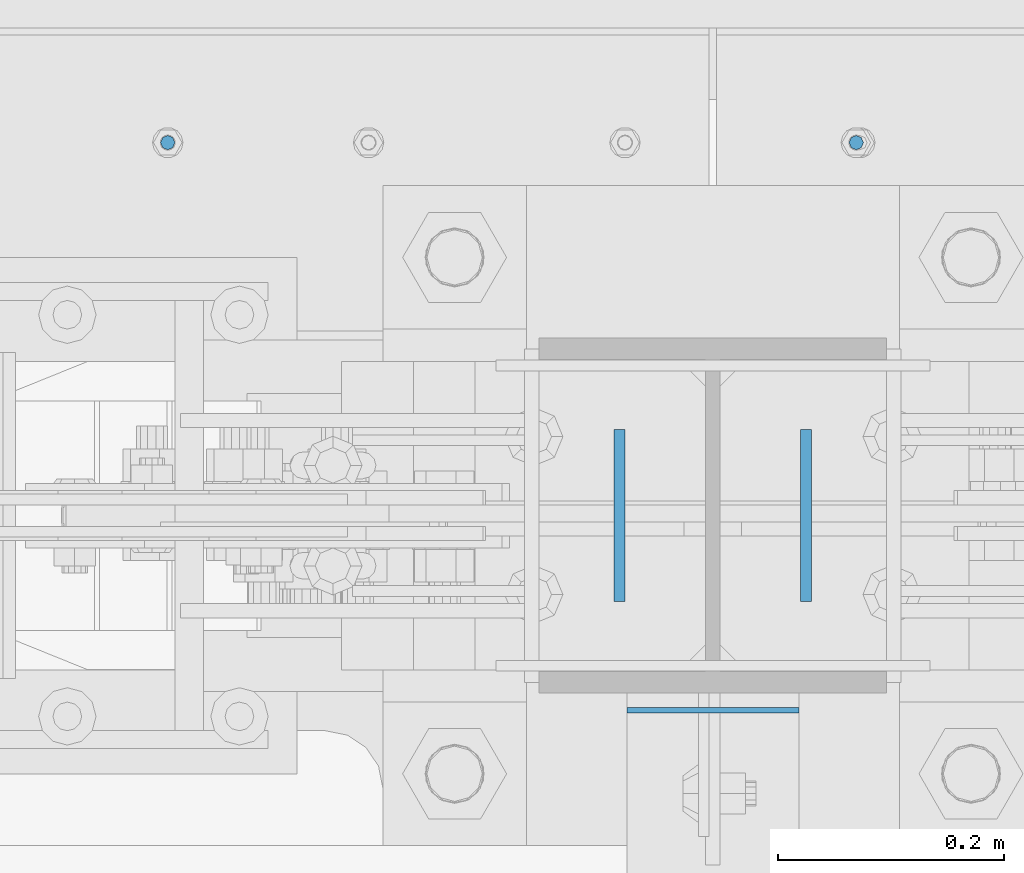
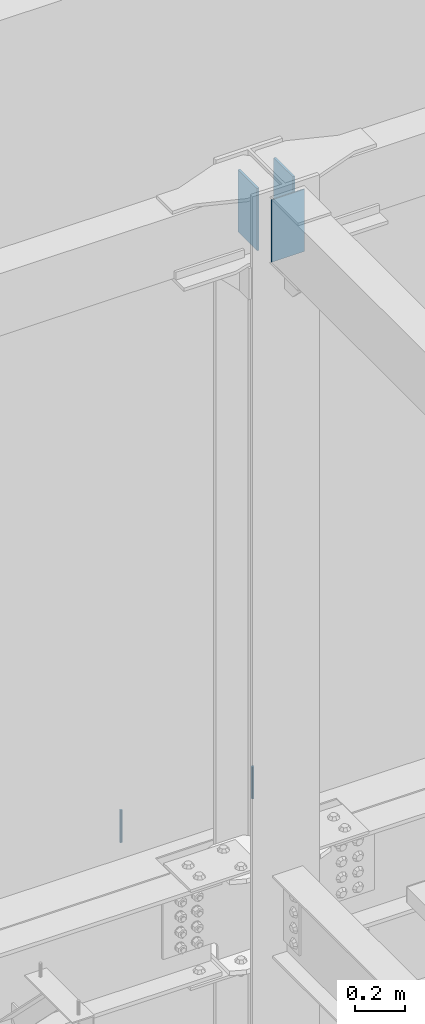
# One storey, part 528 of 1179: 5 columns, 5 elements without a shape of their own.
"""IFC2X3 building model written with IfcOpenShell, lengths in millimetres."""

from ifc_helpers import new_model, si_unit, frame, origin_with_axes, place, context, subcontext, project, spatial, faceted_brep, material, type_object, element, aggregate, save


model = new_model("IFC2X3")

# Units and contexts
model_context = context("Model", 3, precision=1e-05, world=origin_with_axes())
body_context = subcontext(model_context, "Body", "Model", "MODEL_VIEW")
ifc_project = project(units=[si_unit("LENGTHUNIT", "METRE", prefix="MILLI"), si_unit("AREAUNIT", "SQUARE_METRE"), si_unit("VOLUMEUNIT", "CUBIC_METRE"), si_unit("MASSUNIT", "GRAM", prefix="KILO"), si_unit("TIMEUNIT", "SECOND"), si_unit("PLANEANGLEUNIT", "RADIAN"), si_unit("SOLIDANGLEUNIT", "STERADIAN"), si_unit("THERMODYNAMICTEMPERATUREUNIT", "DEGREE_CELSIUS"), si_unit("LUMINOUSINTENSITYUNIT", "LUMEN")], contexts=[model_context])

# Site, building, storey
site_placement = place(None, origin_with_axes())
site = spatial("IfcSite", under=ifc_project, at=site_placement, CompositionType="ELEMENT")
building_placement = place(site_placement, origin_with_axes())
building = spatial("IfcBuilding", under=site, at=building_placement, Name="Undefined", CompositionType="ELEMENT")
storey_placement = place(building_placement, origin_with_axes())
storey = spatial("IfcBuildingStorey", under=building, at=storey_placement, Name="Undefined", CompositionType="ELEMENT", Elevation=0.0)

# Assembly, column
assembly_1_placement = place(storey_placement, origin_with_axes())
assembly_1 = element("IfcElementAssembly", 1, at=assembly_1_placement, inside=storey, Name="BEAM", AssemblyPlace="NOTDEFINED", PredefinedType="RIGID_FRAME")
ifc_material_1 = material(Name="STEEL/A307")
column_type_1 = type_object("IfcColumnType", PredefinedType="NOTDEFINED")
column_1_placement = place(assembly_1_placement, frame((7797.8, 41529.0, 13125.45), z_axis=(0.0, 1.0, 0.0), x_axis=(0.0, 0.0, 1.0)))
column_1 = element("IfcColumn", 2, at=column_1_placement, type_object=column_type_1, material=ifc_material_1, Name="THREADED ROD", context=body_context, shape_type="Brep", body=[
    faceted_brep([(0.0, -6.34999999999854, 0.0), (0.0, -4.49012806053361, -4.49012806053452), (157.162499999999, -4.49012806053361, -4.49012806053361), (157.162499999999, -6.34999999999854, 0.0), (0.0, 0.0, -6.34999999999991), (157.162499999999, 0.0, -6.34999999999854), (0.0, 4.49012806053361, -4.49012806053452), (157.162499999999, 4.49012806053361, -4.49012806053361), (0.0, 6.34999999999854, 0.0), (157.162499999999, 6.34999999999854, 0.0), (0.0, 4.49012806053361, 4.49012806053452), (157.162499999999, 4.49012806053361, 4.49012806053361), (0.0, 0.0, 6.34999999999991), (157.162499999999, 0.0, 6.34999999999854), (0.0, -4.49012806053361, 4.49012806053452), (157.162499999999, -4.49012806053361, 4.49012806053361)], [[[0, 1, 2, 3]], [[1, 4, 5, 2]], [[4, 6, 7, 5]], [[6, 8, 9, 7]], [[8, 10, 11, 9]], [[10, 12, 13, 11]], [[12, 14, 15, 13]], [[14, 0, 3, 15]], [[5, 7, 9, 11, 13, 15, 3, 2]], [[14, 12, 10, 8, 6, 4, 1, 0]]]),
])
aggregate(assembly_1, [column_1])

assembly_2_placement = place(storey_placement, origin_with_axes())
assembly_2 = element("IfcElementAssembly", 3, at=assembly_2_placement, inside=storey, Name="BEAM", AssemblyPlace="NOTDEFINED", PredefinedType="RIGID_FRAME")
column_2_placement = place(assembly_2_placement, frame((8407.4, 41529.0, 13125.45), z_axis=(0.0, 1.0, 0.0), x_axis=(0.0, 0.0, 1.0)))
column_2 = element("IfcColumn", 4, at=column_2_placement, type_object=column_type_1, material=ifc_material_1, Name="THREADED ROD", context=body_context, shape_type="Brep", body=[
    faceted_brep([(0.0, -6.34999999999854, 0.0), (0.0, -4.49012806053361, -4.49012806053452), (157.162499999999, -4.49012806053361, -4.49012806053361), (157.162499999999, -6.34999999999854, 0.0), (0.0, 0.0, -6.34999999999991), (157.162499999999, 0.0, -6.34999999999854), (0.0, 4.49012806053361, -4.49012806053452), (157.162499999999, 4.49012806053361, -4.49012806053361), (0.0, 6.34999999999854, 0.0), (157.162499999999, 6.34999999999854, 0.0), (0.0, 4.49012806053361, 4.49012806053452), (157.162499999999, 4.49012806053361, 4.49012806053361), (0.0, 0.0, 6.34999999999991), (157.162499999999, 0.0, 6.34999999999854), (0.0, -4.49012806053361, 4.49012806053452), (157.162499999999, -4.49012806053361, 4.49012806053361)], [[[0, 1, 2, 3]], [[1, 4, 5, 2]], [[4, 6, 7, 5]], [[6, 8, 9, 7]], [[8, 10, 11, 9]], [[10, 12, 13, 11]], [[12, 14, 15, 13]], [[14, 0, 3, 15]], [[5, 7, 9, 11, 13, 15, 3, 2]], [[14, 12, 10, 8, 6, 4, 1, 0]]]),
])
aggregate(assembly_2, [column_2])

assembly_3_placement = place(storey_placement, origin_with_axes())
assembly_3 = element("IfcElementAssembly", 5, at=assembly_3_placement, inside=storey, Name="BEAM", AssemblyPlace="NOTDEFINED", PredefinedType="RIGID_FRAME")
ifc_material_2 = material(Name="STEEL/A36")
column_type_2 = type_object("IfcColumnType", PredefinedType="NOTDEFINED")
column_3_placement = place(assembly_3_placement, frame((8197.84999897387, 41198.8, 16122.65), z_axis=(0.0, 1.0, 0.0), x_axis=(0.0, 0.0, 1.0)))
column_3 = element("IfcColumn", 6, at=column_3_placement, type_object=column_type_2, material=ifc_material_2, Name="PLATE", context=body_context, shape_type="Brep", body=[
    faceted_brep([(0.0, 4.76249999999982, -76.1999999999971), (0.0, 4.76249999999982, 76.1999999999971), (304.799999999999, 4.76250000000073, 76.1999999999971), (304.799999999999, 4.76250000000073, -76.1999999999971), (0.0, -4.76249999999982, 76.1999999999971), (304.799999999999, -4.76250000000073, 76.1999999999971), (0.0, -4.76249999999982, -76.1999999999971), (304.799999999999, -4.76250000000073, -76.1999999999971)], [[[0, 1, 2, 3]], [[1, 4, 5, 2]], [[4, 6, 7, 5]], [[6, 0, 3, 7]], [[5, 7, 3, 2]], [[6, 4, 1, 0]]]),
])
aggregate(assembly_3, [column_3])

assembly_4_placement = place(storey_placement, origin_with_axes())
assembly_4 = element("IfcElementAssembly", 7, at=assembly_4_placement, inside=storey, Name="BEAM", AssemblyPlace="NOTDEFINED", PredefinedType="RIGID_FRAME")
column_4_placement = place(assembly_4_placement, frame((8362.95000000001, 41198.8, 16122.65), z_axis=(0.0, -1.0, 0.0), x_axis=(0.0, 0.0, 1.0)))
column_4 = element("IfcColumn", 8, at=column_4_placement, type_object=column_type_2, material=ifc_material_2, Name="PLATE", context=body_context, shape_type="Brep", body=[
    faceted_brep([(0.0, 4.76249999999982, -76.1999999999971), (0.0, 4.76249999999982, 76.1999999999971), (304.799999999999, 4.76250000000073, 76.1999999999971), (304.799999999999, 4.76250000000073, -76.1999999999971), (0.0, -4.76249999999982, 76.1999999999971), (304.799999999999, -4.76250000000073, 76.1999999999971), (0.0, -4.76249999999982, -76.1999999999971), (304.799999999999, -4.76250000000073, -76.1999999999971)], [[[0, 1, 2, 3]], [[1, 4, 5, 2]], [[4, 6, 7, 5]], [[6, 0, 3, 7]], [[5, 7, 3, 2]], [[6, 4, 1, 0]]]),
])
aggregate(assembly_4, [column_4])

assembly_5_placement = place(storey_placement, origin_with_axes())
assembly_5 = element("IfcElementAssembly", 9, at=assembly_5_placement, inside=storey, Name="BEAM", AssemblyPlace="NOTDEFINED", PredefinedType="RIGID_FRAME")
column_type_3 = type_object("IfcColumnType", PredefinedType="NOTDEFINED")
column_5_placement = place(assembly_5_placement, frame((8280.4, 41026.5565, 16122.65), z_axis=(-1.0, 0.0, 0.0), x_axis=(0.0, 0.0, 1.0)))
column_5 = element("IfcColumn", 10, at=column_5_placement, type_object=column_type_3, material=ifc_material_2, Name="PLATE", context=body_context, shape_type="Brep", body=[
    faceted_brep([(0.0, 2.38150000000041, -76.1999999999998), (0.0, 2.38150000000041, 76.1999999999998), (304.799999999999, 2.38150000000314, 76.2), (304.799999999999, 2.38150000000314, -76.2), (0.0, -2.38150000000041, 76.1999999999998), (304.799999999999, -2.38150000000314, 76.2), (0.0, -2.38150000000041, -76.1999999999998), (304.799999999999, -2.38150000000314, -76.2)], [[[0, 1, 2, 3]], [[1, 4, 5, 2]], [[4, 6, 7, 5]], [[6, 0, 3, 7]], [[5, 7, 3, 2]], [[6, 4, 1, 0]]]),
])
aggregate(assembly_5, [column_5])

save(model, "model.ifc")
